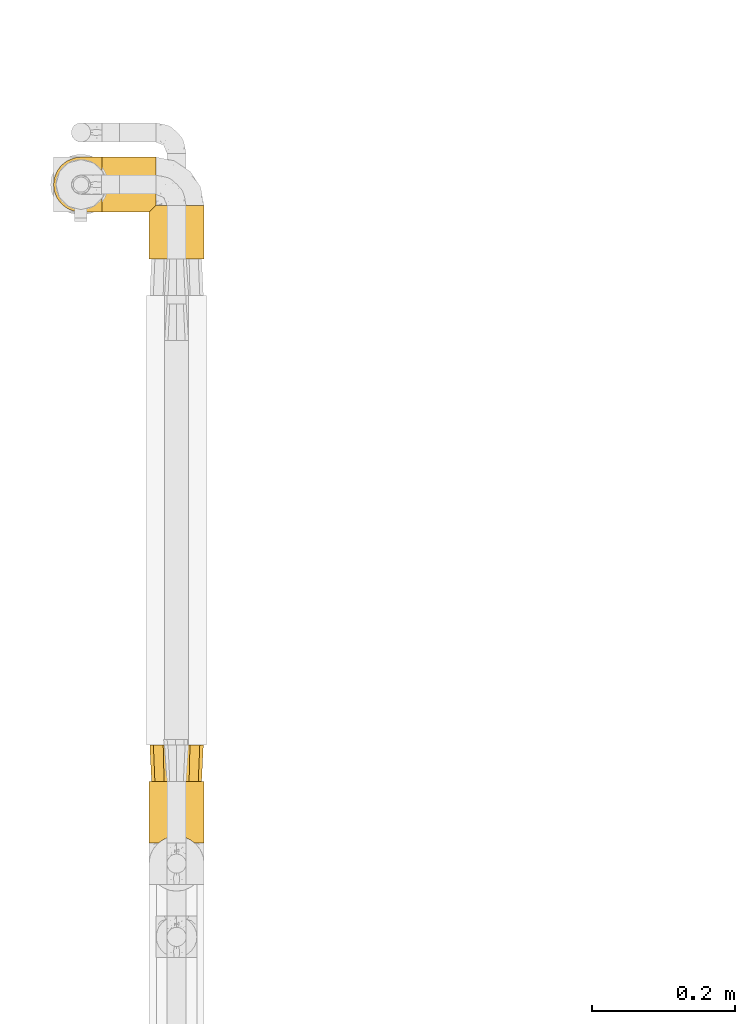
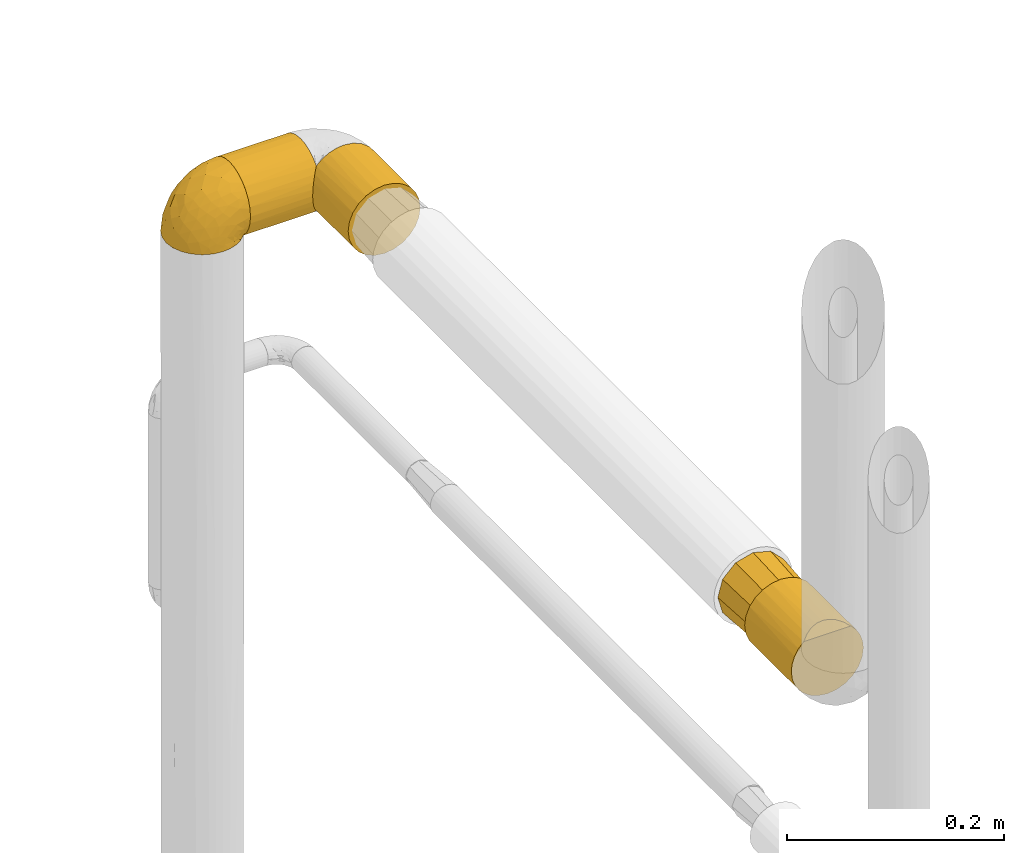
# One storey, part 62 of 827: 5 coverings.
"""IFC2X3 building model written with IfcOpenShell, lengths in millimetres."""

from ifc_helpers import new_model, entity, si_unit, converted_unit, derived_unit, direction, frame, origin, place, context, subcontext, project, spatial, faceted_brep, element, save


model = new_model("IFC2X3")

# Units and contexts
model_context = context("Model", 3, precision=0.01, world=origin(), true_north=direction((6.12303176911189e-17, 1.0)))
body_context = subcontext(model_context, "Body", "Model", "MODEL_VIEW")
ifc_project = project(units=[si_unit("LENGTHUNIT", "METRE", prefix="MILLI"), si_unit("AREAUNIT", "SQUARE_METRE"), si_unit("VOLUMEUNIT", "CUBIC_METRE"), converted_unit("PLANEANGLEUNIT", "DEGREE", entity("IfcRatioMeasure", 0.0174532925199433), si_unit("PLANEANGLEUNIT", "RADIAN"), dimensions=[0, 0, 0, 0, 0, 0, 0]), si_unit("MASSUNIT", "GRAM", prefix="KILO"), derived_unit("MASSDENSITYUNIT", [(si_unit("MASSUNIT", "GRAM", prefix="KILO"), 1), (si_unit("LENGTHUNIT", "METRE"), -3)]), derived_unit("MOMENTOFINERTIAUNIT", [(si_unit("LENGTHUNIT", "METRE"), 4)]), si_unit("TIMEUNIT", "SECOND"), si_unit("FREQUENCYUNIT", "HERTZ"), si_unit("THERMODYNAMICTEMPERATUREUNIT", "DEGREE_CELSIUS"), derived_unit("THERMALTRANSMITTANCEUNIT", [(si_unit("MASSUNIT", "GRAM", prefix="KILO"), 1), (si_unit("THERMODYNAMICTEMPERATUREUNIT", "KELVIN"), -1), (si_unit("TIMEUNIT", "SECOND"), -3)]), derived_unit("VOLUMETRICFLOWRATEUNIT", [(si_unit("LENGTHUNIT", "METRE"), 3), (si_unit("TIMEUNIT", "SECOND"), -1)]), derived_unit("MASSFLOWRATEUNIT", [(si_unit("MASSUNIT", "GRAM", prefix="KILO"), 1), (si_unit("TIMEUNIT", "SECOND"), -1)]), derived_unit("ROTATIONALFREQUENCYUNIT", [(si_unit("TIMEUNIT", "SECOND"), -1)]), si_unit("ELECTRICCURRENTUNIT", "AMPERE"), si_unit("ELECTRICVOLTAGEUNIT", "VOLT"), si_unit("POWERUNIT", "WATT"), si_unit("FORCEUNIT", "NEWTON", prefix="KILO"), si_unit("ILLUMINANCEUNIT", "LUX"), si_unit("LUMINOUSFLUXUNIT", "LUMEN"), si_unit("LUMINOUSINTENSITYUNIT", "CANDELA"), derived_unit("USERDEFINED", [(si_unit("MASSUNIT", "GRAM", prefix="KILO"), -1), (si_unit("LENGTHUNIT", "METRE"), -2), (si_unit("TIMEUNIT", "SECOND"), 3), (si_unit("LUMINOUSFLUXUNIT", "LUMEN"), 1)]), derived_unit("LINEARVELOCITYUNIT", [(si_unit("LENGTHUNIT", "METRE"), 1), (si_unit("TIMEUNIT", "SECOND"), -1)]), si_unit("PRESSUREUNIT", "PASCAL"), derived_unit("USERDEFINED", [(si_unit("LENGTHUNIT", "METRE"), -2), (si_unit("MASSUNIT", "GRAM", prefix="KILO"), 1), (si_unit("TIMEUNIT", "SECOND"), -2)]), derived_unit("LINEARFORCEUNIT", [(si_unit("MASSUNIT", "GRAM", prefix="KILO"), 1), (si_unit("LENGTHUNIT", "METRE"), 1), (si_unit("TIMEUNIT", "SECOND"), -2), (si_unit("LENGTHUNIT", "METRE"), -1)]), derived_unit("PLANARFORCEUNIT", [(si_unit("MASSUNIT", "GRAM", prefix="KILO"), 1), (si_unit("LENGTHUNIT", "METRE"), 1), (si_unit("TIMEUNIT", "SECOND"), -2), (si_unit("LENGTHUNIT", "METRE"), -2)])], contexts=[model_context])

# Site, building, storey
site_placement = place(None, origin())
site = spatial("IfcSite", under=ifc_project, at=site_placement, CompositionType="ELEMENT")
building_placement = place(site_placement, origin())
building = spatial("IfcBuilding", under=site, at=building_placement, CompositionType="ELEMENT")
storey_placement = place(building_placement, frame((0.0, 0.0, 28200.0)))
storey = spatial("IfcBuildingStorey", under=building, at=storey_placement, Name="08", CompositionType="ELEMENT", Elevation=28200.0)

# Coverings
covering_1_placement = place(storey_placement, frame((11891.91, 11247.8, 1505.75)))
element("IfcCovering", 1, at=covering_1_placement, inside=storey, Name=":ADSK_", ObjectType=":ADSK_", PredefinedType="INSULATION", context=body_context, shape_type="Brep", body=[
    faceted_brep([(20.8, 1.6, 6.74), (30.06, 1.6, 2.9), (40.0, 1.6, 1.6), (49.93, 1.6, 2.9), (59.2, 1.6, 6.74), (67.15, 1.6, 12.84), (73.25, 1.6, 20.8), (77.09, 1.6, 30.06), (78.4, 1.6, 40.0), (77.51, 1.6, 48.2), (74.9, 1.6, 56.01), (70.68, 1.6, 63.08), (65.05, 1.6, 69.1), (14.94, 1.6, 69.1), (9.31, 1.6, 63.08), (5.09, 1.6, 56.01), (2.48, 1.6, 48.2), (1.6, 1.6, 40.0), (2.9, 1.6, 30.06), (6.74, 1.6, 20.8), (12.84, 1.6, 12.84), (20.8, 87.5, 6.74), (12.84, 87.5, 12.84), (6.74, 87.5, 20.8), (2.9, 87.5, 30.06), (1.6, 87.5, 40.0), (2.9, 87.5, 49.93), (6.74, 87.5, 59.2), (12.84, 87.5, 67.15), (20.8, 87.5, 73.25), (30.06, 87.5, 77.09), (40.0, 87.5, 78.4), (49.93, 87.5, 77.09), (59.2, 87.5, 73.25), (67.15, 87.5, 67.15), (73.25, 87.5, 59.2), (77.09, 87.5, 49.93), (78.4, 87.5, 40.0), (77.09, 87.5, 30.06), (73.25, 87.5, 20.8), (67.15, 87.5, 12.84), (59.2, 87.5, 6.74), (49.93, 87.5, 2.9), (40.0, 87.5, 1.6), (30.06, 87.5, 2.9), (53.36, 8.5, 76.0), (46.78, 10.29, 77.79), (40.0, 10.9, 78.4), (59.51, 5.57, 73.07), (33.21, 10.29, 77.79), (26.63, 8.5, 76.0), (20.48, 5.57, 73.07)], [[[0, 1, 2, 3, 4, 5, 6, 7, 8, 9, 10, 11, 12, 13, 14, 15, 16, 17, 18, 19, 20]], [[21, 22, 23, 24, 25, 26, 27, 28, 29, 30, 31, 32, 33, 34, 35, 36, 37, 38, 39, 40, 41, 42, 43, 44]], [[24, 23, 19, 18]], [[25, 24, 18, 17]], [[23, 22, 20, 19]], [[1, 0, 21, 44]], [[2, 1, 44, 43]], [[22, 21, 0, 20]], [[3, 2, 43, 42]], [[4, 3, 42, 41]], [[41, 40, 5, 4]], [[7, 6, 39, 38]], [[8, 7, 38, 37]], [[40, 39, 6, 5]], [[9, 37, 36]], [[10, 36, 35]], [[11, 35, 34]], [[8, 37, 9]], [[9, 36, 10]], [[35, 11, 10]], [[34, 12, 11]], [[45, 33, 32]], [[32, 31, 46]], [[47, 46, 31]], [[48, 12, 33]], [[46, 45, 32]], [[48, 33, 45]], [[33, 12, 34]], [[49, 47, 31]], [[49, 31, 30]], [[50, 30, 29]], [[50, 49, 30]], [[13, 51, 29]], [[50, 29, 51]], [[29, 28, 13]], [[14, 28, 27]], [[15, 27, 26]], [[16, 26, 25]], [[14, 27, 15]], [[15, 26, 16]], [[25, 17, 16]], [[28, 14, 13]], [[45, 46, 47, 49, 50, 51, 13, 12, 48]]]),
])
covering_2_placement = place(storey_placement, frame((11825.71, 12130.06, 1505.75)))
element("IfcCovering", 2, at=covering_2_placement, inside=storey, Name=":ADSK_", ObjectType=":ADSK_", PredefinedType="INSULATION", context=body_context, shape_type="Brep", body=[
    faceted_brep([(1.6, 5.09, 23.98), (1.6, 2.48, 31.79), (1.6, 1.6, 40.0), (1.6, 2.9, 49.93), (1.6, 6.74, 59.2), (1.6, 12.84, 67.15), (1.6, 20.8, 73.25), (1.6, 30.06, 77.09), (1.6, 40.0, 78.4), (1.6, 49.93, 77.09), (1.6, 59.2, 73.25), (1.6, 67.15, 67.15), (1.6, 73.25, 59.2), (1.6, 77.09, 49.93), (1.6, 78.4, 40.0), (1.6, 77.51, 31.79), (1.6, 74.9, 23.98), (1.6, 70.68, 16.91), (1.6, 65.05, 10.89), (1.6, 14.94, 10.9), (1.6, 9.31, 16.91), (77.1, 10.89, 65.05), (77.1, 10.9, 14.94), (77.1, 16.91, 9.31), (77.1, 23.98, 5.09), (77.1, 31.79, 2.48), (77.1, 40.0, 1.6), (77.1, 49.93, 2.9), (77.1, 59.2, 6.74), (77.1, 67.15, 12.84), (77.1, 73.25, 20.8), (77.1, 77.09, 30.06), (77.1, 78.4, 40.0), (77.1, 77.09, 49.93), (77.1, 73.25, 59.2), (77.1, 67.15, 67.15), (77.1, 59.2, 73.25), (77.1, 49.93, 77.09), (77.1, 40.0, 78.4), (77.1, 31.79, 77.51), (77.1, 23.98, 74.9), (77.1, 16.91, 70.68), (8.5, 53.36, 4.0), (10.29, 46.78, 2.2), (10.9, 40.0, 1.6), (5.57, 59.51, 6.92), (10.29, 33.21, 2.2), (8.5, 26.63, 4.0), (5.57, 20.48, 6.92), (73.13, 6.92, 20.48), (70.2, 4.0, 26.63), (68.41, 2.2, 33.21), (67.8, 1.6, 40.0), (68.41, 2.2, 46.78), (70.2, 4.0, 53.36), (73.13, 6.92, 59.51)], [[[0, 1, 2, 3, 4, 5, 6, 7, 8, 9, 10, 11, 12, 13, 14, 15, 16, 17, 18, 19, 20]], [[21, 22, 23, 24, 25, 26, 27, 28, 29, 30, 31, 32, 33, 34, 35, 36, 37, 38, 39, 40, 41]], [[32, 31, 15]], [[30, 29, 17]], [[31, 30, 16]], [[14, 32, 15]], [[17, 16, 30]], [[31, 16, 15]], [[29, 18, 17]], [[42, 28, 27]], [[27, 26, 43]], [[44, 43, 26]], [[45, 18, 28]], [[43, 42, 27]], [[45, 28, 42]], [[28, 18, 29]], [[46, 26, 25]], [[47, 25, 24]], [[48, 24, 23]], [[46, 44, 26]], [[48, 47, 24]], [[19, 48, 23]], [[46, 25, 47]], [[23, 22, 19]], [[22, 49, 20]], [[50, 51, 1]], [[49, 50, 0]], [[20, 49, 0]], [[51, 2, 1]], [[1, 0, 50]], [[2, 51, 52]], [[22, 20, 19]], [[53, 54, 3]], [[55, 21, 4]], [[54, 55, 4]], [[52, 53, 2]], [[2, 53, 3]], [[54, 4, 3]], [[21, 5, 4]], [[6, 41, 40]], [[7, 40, 39]], [[8, 39, 38]], [[5, 41, 6]], [[6, 40, 7]], [[39, 8, 7]], [[41, 5, 21]], [[9, 8, 38, 37]], [[10, 9, 37, 36]], [[36, 35, 11, 10]], [[13, 12, 34, 33]], [[14, 13, 33, 32]], [[35, 34, 12, 11]], [[18, 45, 42, 43, 44, 46, 47, 48, 19]], [[51, 50, 49, 22, 21, 55, 54, 53, 52]]]),
])
covering_3_placement = place(storey_placement, frame((11758.16, 12130.01, 1515.05)))
element("IfcCovering", 3, at=covering_3_placement, inside=storey, Name=":ADSK_", ObjectType=":ADSK_", PredefinedType="INSULATION", context=body_context, shape_type="Brep", body=[
    faceted_brep([(69.15, 74.69, 47.38), (69.15, 70.1, 54.67), (69.15, 64.01, 60.76), (69.15, 56.72, 65.34), (69.15, 48.6, 68.18), (69.15, 40.05, 69.15), (69.15, 31.49, 68.18), (69.15, 23.36, 65.34), (69.15, 16.07, 60.75), (69.15, 9.98, 54.66), (69.15, 5.4, 47.37), (69.15, 2.56, 39.25), (69.15, 1.6, 30.7), (69.15, 2.46, 22.6), (69.15, 5.01, 14.86), (69.15, 9.13, 7.84), (69.15, 14.62, 1.85), (69.15, 16.82, 1.85), (69.15, 18.56, 1.85), (69.15, 20.52, 1.85), (69.15, 22.49, 1.85), (69.15, 24.46, 1.85), (69.15, 26.42, 1.85), (69.15, 28.39, 1.85), (69.15, 30.36, 1.85), (69.15, 32.55, 1.85), (69.15, 34.75, 1.85), (69.15, 36.94, 1.85), (69.15, 39.13, 1.85), (69.15, 41.33, 1.85), (69.15, 43.52, 1.85), (69.15, 45.72, 1.85), (69.15, 47.91, 1.85), (69.15, 50.11, 1.85), (69.15, 52.3, 1.85), (69.15, 54.49, 1.85), (69.15, 56.69, 1.85), (69.15, 58.88, 1.85), (69.15, 61.08, 1.85), (69.15, 63.27, 1.85), (69.15, 65.47, 1.85), (69.15, 70.97, 7.85), (69.15, 75.09, 14.88), (69.15, 77.64, 22.61), (69.15, 78.5, 30.7), (69.15, 77.53, 39.26), (68.89, 14.62, 1.6), (62.89, 9.12, 1.6), (55.87, 5.0, 1.6), (48.14, 2.46, 1.6), (40.05, 1.6, 1.6), (30.09, 2.91, 1.6), (20.82, 6.75, 1.6), (12.86, 12.86, 1.6), (6.75, 20.82, 1.6), (2.91, 30.09, 1.6), (1.6, 40.05, 1.6), (2.91, 50.0, 1.6), (6.75, 59.27, 1.6), (12.86, 67.23, 1.6), (20.82, 73.34, 1.6), (30.09, 77.19, 1.6), (40.05, 78.5, 1.6), (48.14, 77.63, 1.6), (55.87, 75.09, 1.6), (62.89, 70.97, 1.6), (68.89, 65.47, 1.6), (68.89, 63.27, 1.6), (68.89, 62.29, 1.6), (68.89, 60.7, 1.6), (68.89, 59.11, 1.6), (68.89, 57.52, 1.6), (68.89, 55.93, 1.6), (68.89, 54.34, 1.6), (68.89, 52.76, 1.6), (68.89, 51.17, 1.6), (68.89, 49.58, 1.6), (68.89, 47.99, 1.6), (68.89, 46.4, 1.6), (68.89, 44.81, 1.6), (68.89, 43.22, 1.6), (68.89, 41.63, 1.6), (68.89, 40.05, 1.6), (68.89, 38.46, 1.6), (68.89, 36.87, 1.6), (68.89, 35.28, 1.6), (68.89, 33.69, 1.6), (68.89, 32.1, 1.6), (68.89, 30.51, 1.6), (68.89, 28.92, 1.6), (68.89, 27.33, 1.6), (68.89, 25.37, 1.6), (68.89, 23.4, 1.6), (68.89, 21.21, 1.6), (68.89, 19.01, 1.6), (68.89, 16.82, 1.6), (68.97, 42.32, 1.78), (68.96, 44.02, 1.77), (68.97, 47.13, 1.78), (68.97, 48.74, 1.77), (68.98, 23.57, 1.79), (68.97, 25.13, 1.78), (68.96, 61.34, 1.76), (68.96, 22.02, 1.77), (68.96, 29.72, 1.77), (68.96, 56.73, 1.76), (68.96, 55.14, 1.77), (68.96, 37.66, 1.77), (69.0, 64.12, 1.8), (68.96, 28.13, 1.76), (68.96, 26.62, 1.77), (68.97, 31.46, 1.78), (68.96, 16.16, 1.77), (68.96, 39.16, 1.77), (68.96, 50.37, 1.76), (68.97, 17.69, 1.78), (68.97, 19.17, 1.78), (68.97, 62.78, 1.77), (68.96, 58.35, 1.77), (68.96, 45.53, 1.77), (68.97, 59.91, 1.78), (68.97, 65.47, 1.77), (69.02, 65.47, 1.8), (69.08, 65.47, 1.82), (68.97, 14.62, 1.78), (68.94, 14.62, 1.72), (68.96, 20.59, 1.76), (68.96, 32.99, 1.77), (68.95, 34.48, 1.76), (68.96, 51.91, 1.77), (68.92, 65.47, 1.66), (68.98, 53.48, 1.78), (69.08, 14.62, 1.82), (69.02, 14.62, 1.8), (68.96, 40.77, 1.77), (68.97, 35.97, 1.78), (68.92, 14.62, 1.66), (61.33, 7.84, 3.72), (53.1, 3.53, 7.41), (63.33, 8.32, 6.14), (55.53, 2.19, 19.34), (63.33, 3.53, 17.64), (54.6, 1.6, 26.8), (41.99, 1.6, 8.87), (57.07, 4.57, 9.2), (57.95, 3.96, 12.79), (51.56, 2.28, 14.62), (41.58, 1.6, 7.34), (61.7, 7.69, 5.33), (65.0, 8.32, 7.7), (67.02, 7.84, 9.41), (61.87, 1.6, 28.75), (49.27, 1.6, 21.47), (43.94, 1.6, 16.15), (61.21, 4.34, 14.14), (63.4, 1.6, 29.16), (33.11, 29.63, 57.02), (52.82, 27.34, 64.92), (43.3, 40.05, 64.0), (33.73, 2.39, 11.92), (36.52, 2.43, 19.16), (24.87, 9.07, 28.65), (14.17, 16.64, 24.62), (18.43, 9.54, 15.19), (28.67, 4.52, 18.36), (26.0, 4.52, 9.21), (49.25, 7.49, 46.98), (59.72, 7.49, 50.24), (55.1, 12.85, 56.1), (44.72, 2.35, 28.97), (34.15, 22.67, 54.46), (5.25, 32.9, 21.34), (6.75, 25.33, 18.4), (55.54, 40.05, 66.44), (10.47, 16.64, 12.08), (25.49, 19.99, 45.49), (35.53, 16.37, 50.57), (48.22, 3.26, 36.04), (58.71, 3.75, 42.07), (57.42, 19.58, 62.12), (34.84, 7.5, 37.37), (36.87, 4.04, 29.39), (45.01, 13.94, 53.59), (44.4, 19.58, 58.06), (23.96, 28.21, 49.27), (11.2, 24.75, 29.63), (10.56, 31.42, 33.21), (16.81, 26.2, 40.1), (17.38, 33.36, 44.08), (21.38, 40.05, 49.36), (32.34, 40.05, 56.68), (4.3, 40.05, 15.2), (20.65, 16.14, 35.57), (29.66, 12.85, 41.7), (39.6, 10.47, 46.4), (42.55, 6.49, 41.41), (6.74, 40.05, 27.45), (14.06, 40.05, 38.4), (26.84, 75.57, 12.99), (5.28, 47.37, 21.33), (18.52, 52.91, 42.89), (33.13, 50.46, 57.04), (55.1, 67.23, 56.11), (57.43, 60.5, 62.13), (20.72, 70.55, 21.89), (11.46, 63.45, 16.62), (17.69, 62.62, 32.9), (49.26, 72.6, 46.99), (59.73, 72.6, 50.25), (58.71, 76.34, 42.08), (29.72, 59.34, 49.92), (35.35, 77.76, 15.6), (43.94, 78.5, 16.15), (41.99, 78.5, 8.87), (63.4, 78.5, 29.16), (4.93, 53.16, 13.16), (17.46, 70.55, 10.83), (10.94, 48.88, 33.8), (8.92, 54.76, 25.02), (52.83, 52.74, 64.92), (29.34, 71.93, 32.83), (30.26, 75.79, 20.56), (44.4, 60.5, 58.07), (39.06, 77.86, 21.46), (43.06, 77.64, 28.1), (54.6, 78.5, 26.8), (49.27, 78.5, 21.47), (42.69, 67.23, 51.29), (48.2, 76.82, 36.04), (61.87, 78.5, 28.75), (33.44, 77.8, 8.45), (29.67, 67.23, 41.73), (38.5, 73.21, 39.27), (23.35, 67.66, 33.56), (34.97, 75.99, 27.29), (53.1, 76.57, 7.41), (59.68, 73.21, 3.51), (62.19, 71.93, 4.68), (68.94, 65.47, 1.72), (64.11, 71.07, 5.52), (57.97, 75.09, 8.75), (57.95, 76.13, 12.79), (63.33, 76.57, 17.65), (51.77, 77.69, 13.9), (67.02, 72.26, 9.42), (64.98, 71.77, 7.68), (55.53, 77.9, 19.33), (61.22, 75.75, 14.13)], [[[0, 1, 2, 3, 4, 5, 6, 7, 8, 9, 10, 11, 12, 13, 14, 15, 16, 17, 18, 19, 20, 21, 22, 23, 24, 25, 26, 27, 28, 29, 30, 31, 32, 33, 34, 35, 36, 37, 38, 39, 40, 41, 42, 43, 44, 45]], [[46, 47, 48, 49, 50, 51, 52, 53, 54, 55, 56, 57, 58, 59, 60, 61, 62, 63, 64, 65, 66, 67, 68, 69, 70, 71, 72, 73, 74, 75, 76, 77, 78, 79, 80, 81, 82, 83, 84, 85, 86, 87, 88, 89, 90, 91, 92, 93, 94, 95]], [[96, 97, 30]], [[98, 77, 99]], [[100, 101, 21]], [[69, 68, 102]], [[20, 19, 103]], [[24, 23, 104]], [[20, 103, 100]], [[72, 105, 106]], [[84, 83, 107]], [[89, 88, 104]], [[108, 67, 66]], [[109, 110, 90]], [[111, 25, 24]], [[112, 17, 16]], [[82, 113, 83]], [[109, 23, 22]], [[114, 76, 75]], [[105, 36, 106]], [[104, 111, 24]], [[18, 115, 116]], [[97, 96, 80]], [[67, 108, 117]], [[105, 71, 118]], [[31, 97, 119]], [[102, 120, 69]], [[108, 121, 122, 123, 40]], [[112, 95, 115]], [[17, 115, 18]], [[94, 116, 115]], [[117, 68, 67]], [[38, 117, 39]], [[112, 124, 125]], [[17, 112, 115]], [[70, 120, 118]], [[39, 117, 108]], [[120, 38, 37]], [[120, 37, 118]], [[120, 70, 69]], [[116, 94, 126]], [[127, 86, 128]], [[117, 38, 102]], [[74, 129, 75]], [[99, 33, 32]], [[115, 95, 94]], [[39, 108, 40]], [[108, 66, 130]], [[105, 72, 71]], [[118, 37, 36]], [[71, 70, 118]], [[35, 106, 36]], [[36, 105, 118]], [[35, 131, 106]], [[74, 73, 131]], [[106, 131, 73]], [[99, 114, 33]], [[131, 35, 34]], [[73, 72, 106]], [[95, 112, 46]], [[112, 16, 132, 133, 124]], [[129, 114, 75]], [[99, 76, 114]], [[114, 129, 33]], [[34, 33, 129]], [[78, 77, 98]], [[98, 119, 78]], [[129, 131, 34]], [[131, 129, 74]], [[79, 97, 80]], [[98, 99, 32]], [[98, 32, 31]], [[77, 76, 99]], [[97, 79, 119]], [[134, 96, 29]], [[30, 97, 31]], [[134, 29, 28]], [[81, 80, 96]], [[29, 96, 30]], [[31, 119, 98]], [[119, 79, 78]], [[96, 134, 81]], [[82, 81, 134]], [[113, 107, 83]], [[84, 107, 135]], [[107, 27, 135]], [[113, 28, 107]], [[27, 107, 28]], [[85, 84, 135]], [[135, 27, 26]], [[113, 134, 28]], [[134, 113, 82]], [[109, 89, 104]], [[86, 85, 128]], [[89, 109, 90]], [[111, 87, 127]], [[26, 128, 135]], [[88, 111, 104]], [[25, 111, 127]], [[22, 110, 109]], [[23, 109, 104]], [[110, 91, 90]], [[100, 92, 101]], [[110, 22, 101]], [[91, 110, 101]], [[116, 19, 18]], [[111, 88, 87]], [[126, 103, 19]], [[25, 127, 26]], [[86, 127, 87]], [[127, 128, 26]], [[135, 128, 85]], [[120, 102, 38]], [[117, 102, 68]], [[91, 101, 92]], [[21, 101, 22]], [[93, 92, 103]], [[100, 21, 20]], [[100, 103, 92]], [[126, 93, 103]], [[93, 126, 94]], [[116, 126, 19]], [[136, 137, 47]], [[48, 137, 138]], [[139, 125, 124]], [[140, 141, 142]], [[143, 49, 138]], [[144, 139, 145]], [[48, 138, 49]], [[138, 144, 146]], [[49, 143, 147, 50]], [[136, 125, 148]], [[14, 13, 141]], [[149, 145, 139]], [[148, 139, 144]], [[150, 149, 133]], [[150, 14, 141]], [[16, 15, 132]], [[13, 151, 141]], [[124, 149, 139]], [[140, 142, 152]], [[14, 150, 15]], [[15, 150, 132]], [[47, 46, 136]], [[138, 153, 143]], [[137, 48, 47]], [[125, 139, 148]], [[133, 132, 150]], [[145, 154, 140]], [[144, 145, 146]], [[148, 138, 137]], [[146, 152, 153]], [[146, 145, 140]], [[138, 146, 153]], [[138, 148, 144]], [[148, 137, 136]], [[146, 140, 152]], [[145, 149, 154]], [[150, 154, 149]], [[141, 140, 154]], [[13, 12, 155, 151]], [[151, 142, 141]], [[150, 141, 154]], [[149, 124, 133]], [[156, 157, 158]], [[159, 153, 160]], [[161, 162, 163]], [[164, 165, 159]], [[166, 167, 168]], [[152, 169, 160]], [[155, 12, 11]], [[157, 156, 170]], [[171, 55, 172]], [[157, 6, 173]], [[174, 54, 53]], [[52, 165, 163]], [[52, 163, 53]], [[54, 174, 172]], [[165, 52, 51]], [[175, 176, 170]], [[177, 142, 178]], [[155, 11, 178]], [[8, 7, 179]], [[168, 9, 8]], [[178, 142, 151, 155]], [[178, 11, 10]], [[167, 178, 10]], [[180, 161, 181]], [[178, 166, 177]], [[182, 183, 176]], [[182, 168, 183]], [[175, 170, 184]], [[171, 185, 186]], [[157, 7, 6]], [[158, 157, 173]], [[183, 179, 157]], [[54, 172, 55]], [[179, 168, 8]], [[187, 188, 186]], [[9, 167, 10]], [[185, 187, 186]], [[189, 156, 158, 190]], [[55, 171, 191]], [[175, 192, 193]], [[160, 169, 181]], [[161, 163, 164]], [[174, 163, 162]], [[51, 50, 147]], [[166, 194, 195]], [[177, 181, 169]], [[6, 5, 173]], [[157, 179, 7]], [[168, 179, 183]], [[168, 167, 9]], [[178, 167, 166]], [[181, 161, 164]], [[161, 193, 192]], [[160, 164, 159]], [[194, 180, 195]], [[191, 171, 196]], [[191, 56, 55]], [[188, 189, 197]], [[197, 196, 186]], [[171, 186, 196]], [[184, 188, 187]], [[197, 186, 188]], [[185, 171, 172]], [[172, 162, 185]], [[192, 185, 162]], [[175, 184, 187]], [[184, 156, 189]], [[187, 185, 192]], [[176, 175, 193]], [[187, 192, 175]], [[161, 192, 162]], [[194, 176, 193]], [[170, 176, 183]], [[180, 194, 193]], [[182, 166, 168]], [[161, 180, 193]], [[195, 181, 177]], [[157, 170, 183]], [[170, 156, 184]], [[176, 194, 182]], [[166, 182, 194]], [[181, 195, 180]], [[177, 169, 142]], [[177, 166, 195]], [[163, 174, 53]], [[172, 174, 162]], [[159, 51, 147]], [[163, 165, 164]], [[51, 159, 165]], [[159, 147, 143, 153]], [[152, 160, 153]], [[181, 164, 160]], [[189, 188, 184]], [[142, 169, 152]], [[60, 198, 61]], [[196, 199, 191]], [[200, 189, 201]], [[199, 57, 191]], [[202, 203, 2]], [[204, 205, 206]], [[207, 208, 209]], [[210, 206, 200]], [[211, 212, 213]], [[45, 214, 209]], [[215, 205, 58]], [[45, 44, 214]], [[59, 216, 60]], [[60, 216, 198]], [[0, 45, 209]], [[217, 200, 218]], [[201, 158, 219]], [[204, 220, 221]], [[222, 203, 202]], [[1, 202, 2]], [[57, 199, 215]], [[219, 3, 203]], [[219, 173, 4]], [[1, 0, 208]], [[211, 223, 212]], [[224, 225, 226]], [[227, 222, 202]], [[207, 209, 228]], [[209, 225, 228]], [[3, 219, 4]], [[58, 205, 59]], [[208, 202, 1]], [[201, 219, 222]], [[227, 202, 207]], [[201, 210, 200]], [[3, 2, 203]], [[201, 189, 190, 158]], [[209, 214, 229, 225]], [[198, 211, 230]], [[231, 232, 220]], [[232, 207, 228]], [[206, 205, 218]], [[216, 205, 204]], [[226, 223, 224]], [[232, 231, 227]], [[200, 206, 218]], [[233, 231, 220]], [[217, 218, 199]], [[201, 222, 210]], [[173, 219, 158]], [[173, 5, 4]], [[61, 230, 62]], [[219, 203, 222]], [[209, 208, 0]], [[202, 208, 207]], [[224, 232, 228]], [[223, 226, 212]], [[220, 232, 234]], [[57, 56, 191]], [[197, 217, 196]], [[199, 218, 215]], [[200, 197, 189]], [[196, 217, 199]], [[197, 200, 217]], [[205, 215, 218]], [[58, 57, 215]], [[230, 211, 213]], [[221, 211, 198]], [[227, 210, 222]], [[206, 210, 231]], [[62, 230, 213]], [[198, 230, 61]], [[232, 227, 207]], [[210, 227, 231]], [[221, 220, 234]], [[233, 204, 206]], [[205, 216, 59]], [[198, 216, 204]], [[204, 221, 198]], [[223, 221, 234]], [[221, 223, 211]], [[223, 234, 224]], [[232, 224, 234]], [[225, 224, 228]], [[204, 233, 220]], [[206, 231, 233]], [[63, 213, 235]], [[213, 212, 235]], [[213, 63, 62]], [[236, 235, 237]], [[237, 238, 130]], [[235, 236, 64]], [[239, 240, 241]], [[63, 235, 64]], [[130, 66, 65]], [[236, 130, 65]], [[242, 229, 43]], [[236, 65, 64]], [[239, 121, 238]], [[42, 242, 43]], [[241, 240, 243]], [[41, 123, 244]], [[43, 229, 214, 44]], [[244, 122, 245]], [[226, 246, 243]], [[245, 241, 247]], [[121, 239, 245]], [[41, 40, 123]], [[238, 237, 239]], [[244, 42, 41]], [[130, 236, 237]], [[240, 239, 237]], [[245, 239, 241]], [[247, 241, 246]], [[247, 244, 245]], [[237, 235, 240]], [[243, 235, 212]], [[235, 243, 240]], [[246, 241, 243]], [[243, 212, 226]], [[225, 242, 246]], [[226, 225, 246]], [[246, 242, 247]], [[244, 247, 242]], [[242, 225, 229]], [[42, 244, 242]], [[122, 244, 123]], [[122, 121, 245]], [[112, 125, 136]], [[112, 136, 46]], [[108, 130, 238]], [[108, 238, 121]]]),
])
covering_4_placement = place(storey_placement, frame((11891.91, 12066.3, 1505.75)))
element("IfcCovering", 4, at=covering_4_placement, inside=storey, Name=":ADSK_", ObjectType=":ADSK_", PredefinedType="INSULATION", context=body_context, shape_type="Brep", body=[
    faceted_brep([(31.79, 74.65, 77.51), (40.0, 74.65, 78.4), (49.93, 74.65, 77.09), (59.2, 74.65, 73.25), (67.15, 74.65, 67.15), (73.25, 74.65, 59.2), (77.09, 74.65, 49.93), (78.4, 74.65, 40.0), (77.09, 74.65, 30.06), (73.25, 74.65, 20.8), (67.15, 74.65, 12.84), (59.2, 74.65, 6.74), (49.93, 74.65, 2.9), (40.0, 74.65, 1.6), (31.79, 74.65, 2.48), (23.98, 74.65, 5.09), (16.91, 74.65, 9.31), (10.89, 74.65, 14.94), (10.9, 74.65, 65.05), (16.91, 74.65, 70.68), (23.98, 74.65, 74.9), (20.8, 0.0, 73.25), (12.84, 0.0, 67.15), (6.74, 0.0, 59.2), (2.9, 0.0, 49.93), (1.6, 0.0, 40.0), (2.9, 0.0, 30.06), (6.74, 0.0, 20.8), (12.84, 0.0, 12.84), (20.8, 0.0, 6.74), (30.06, 0.0, 2.9), (40.0, 0.0, 1.6), (49.93, 0.0, 2.9), (59.2, 0.0, 6.74), (67.15, 0.0, 12.84), (73.25, 0.0, 20.8), (77.09, 0.0, 30.06), (78.4, 0.0, 40.0), (77.09, 0.0, 49.93), (73.25, 0.0, 59.2), (67.15, 0.0, 67.15), (59.2, 0.0, 73.25), (49.93, 0.0, 77.09), (40.0, 0.0, 78.4), (30.06, 0.0, 77.09), (4.0, 67.75, 26.63), (2.2, 65.96, 33.21), (1.6, 65.35, 40.0), (6.92, 70.68, 20.48), (2.2, 65.96, 46.78), (4.0, 67.75, 53.36), (6.92, 70.68, 59.51)], [[[0, 1, 2, 3, 4, 5, 6, 7, 8, 9, 10, 11, 12, 13, 14, 15, 16, 17, 18, 19, 20]], [[21, 22, 23, 24, 25, 26, 27, 28, 29, 30, 31, 32, 33, 34, 35, 36, 37, 38, 39, 40, 41, 42, 43, 44]], [[36, 35, 9, 8]], [[37, 36, 8, 7]], [[10, 9, 35, 34]], [[12, 11, 33, 32]], [[13, 12, 32, 31]], [[34, 33, 11, 10]], [[14, 31, 30]], [[15, 30, 29]], [[16, 29, 28]], [[13, 31, 14]], [[14, 30, 15]], [[29, 16, 15]], [[28, 17, 16]], [[45, 27, 26]], [[26, 25, 46]], [[47, 46, 25]], [[48, 17, 27]], [[46, 45, 26]], [[48, 27, 45]], [[27, 17, 28]], [[49, 47, 25]], [[49, 25, 24]], [[50, 24, 23]], [[50, 49, 24]], [[18, 51, 23]], [[50, 23, 51]], [[23, 22, 18]], [[19, 22, 21]], [[20, 21, 44]], [[0, 44, 43]], [[19, 21, 20]], [[20, 44, 0]], [[43, 1, 0]], [[22, 19, 18]], [[2, 1, 43, 42]], [[3, 2, 42, 41]], [[41, 40, 4, 3]], [[6, 5, 39, 38]], [[7, 6, 38, 37]], [[40, 39, 5, 4]], [[47, 49, 50, 51, 18, 17, 48, 45, 46]]]),
])
covering_5_placement = place(storey_placement, frame((11892.81, 11335.3, 1506.65)))
element("IfcCovering", 5, at=covering_5_placement, inside=storey, Name=":ADSK_", ObjectType=":ADSK_", PredefinedType="INSULATION", context=body_context, shape_type="Brep", body=[
    faceted_brep([(57.85, 51.0, 6.62), (51.96, 51.0, 5.04), (45.53, 51.0, 3.32), (39.1, 51.0, 1.6), (32.66, 51.0, 3.32), (26.23, 51.0, 5.04), (20.35, 51.0, 6.62), (13.48, 51.0, 13.48), (6.62, 51.0, 20.35), (5.04, 51.0, 26.23), (3.32, 51.0, 32.66), (1.6, 51.0, 39.1), (3.32, 51.0, 45.53), (5.04, 51.0, 51.96), (6.62, 51.0, 57.85), (13.48, 51.0, 64.71), (20.35, 51.0, 71.57), (26.23, 51.0, 73.15), (32.66, 51.0, 74.87), (39.1, 51.0, 76.6), (45.53, 51.0, 74.87), (51.96, 51.0, 73.15), (57.85, 51.0, 71.57), (64.71, 51.0, 64.71), (71.57, 51.0, 57.85), (73.15, 51.0, 51.96), (74.87, 51.0, 45.53), (76.6, 51.0, 39.1), (74.87, 51.0, 32.66), (73.15, 51.0, 26.23), (71.57, 51.0, 20.35), (64.71, 51.0, 13.48), (30.35, 0.0, 71.75), (21.6, 0.0, 69.41), (15.19, 0.0, 63.0), (8.78, 0.0, 56.6), (6.44, 0.0, 47.85), (4.1, 0.0, 39.1), (6.44, 0.0, 30.35), (8.78, 0.0, 21.6), (15.19, 0.0, 15.19), (21.6, 0.0, 8.78), (30.35, 0.0, 6.44), (39.1, 0.0, 4.1), (47.85, 0.0, 6.44), (56.6, 0.0, 8.78), (63.0, 0.0, 15.19), (69.41, 0.0, 21.6), (71.75, 0.0, 30.35), (74.1, 0.0, 39.1), (71.75, 0.0, 47.85), (69.41, 0.0, 56.6), (63.0, 0.0, 63.0), (56.6, 0.0, 69.41), (47.85, 0.0, 71.75), (39.1, 0.0, 74.1)], [[[0, 1, 2, 3, 4, 5, 6, 7, 8, 9, 10, 11, 12, 13, 14, 15, 16, 17, 18, 19, 20, 21, 22, 23, 24, 25, 26, 27, 28, 29, 30, 31]], [[32, 33, 34, 35, 36, 37, 38, 39, 40, 41, 42, 43, 44, 45, 46, 47, 48, 49, 50, 51, 52, 53, 54, 55]], [[47, 30, 29, 28, 27, 49, 48]], [[43, 3, 2, 1, 0, 45, 44]], [[31, 30, 47, 46, 45, 0]], [[41, 6, 5, 4, 3, 43, 42]], [[37, 11, 10, 9, 8, 39, 38]], [[7, 6, 41, 40, 39, 8]], [[35, 14, 13, 12, 11, 37, 36]], [[55, 19, 18, 17, 16, 33, 32]], [[15, 14, 35, 34, 33, 16]], [[53, 22, 21, 20, 19, 55, 54]], [[49, 27, 26, 25, 24, 51, 50]], [[23, 22, 53, 52, 51, 24]]]),
])

save(model, "model.ifc")
